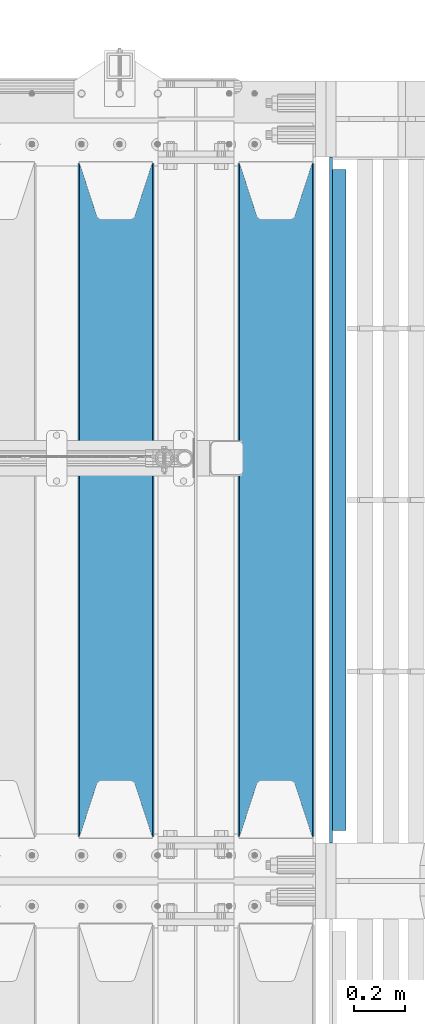
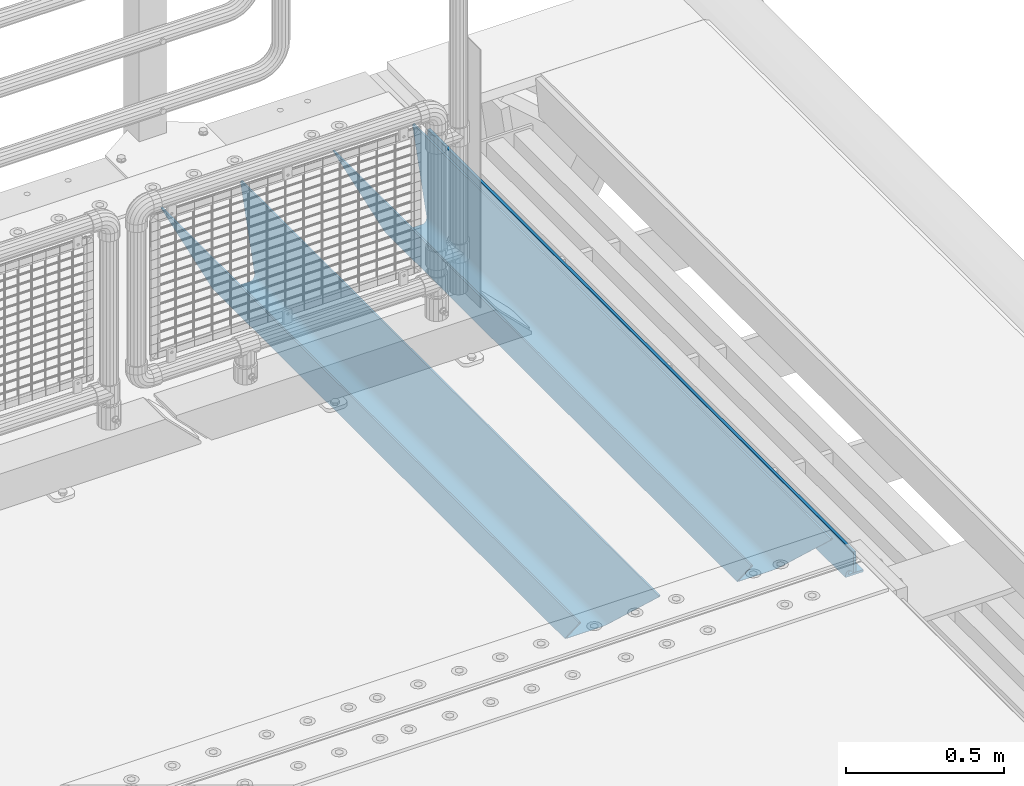
# One storey, part 135 of 247: 3 beams.
"""IFC2X3 building model written with IfcOpenShell, lengths in millimetres."""

from ifc_helpers import new_model, si_unit, frame, origin_with_axes, place, context, subcontext, project, spatial, faceted_brep, material, type_object, element, save


model = new_model("IFC2X3")

# Units and contexts
model_context = context("Model", 3, precision=1e-05, world=origin_with_axes())
body_context = subcontext(model_context, "Body", "Model", "MODEL_VIEW")
ifc_project = project(units=[si_unit("LENGTHUNIT", "METRE", prefix="MILLI"), si_unit("AREAUNIT", "SQUARE_METRE"), si_unit("VOLUMEUNIT", "CUBIC_METRE"), si_unit("MASSUNIT", "GRAM", prefix="KILO"), si_unit("TIMEUNIT", "SECOND"), si_unit("PLANEANGLEUNIT", "RADIAN"), si_unit("SOLIDANGLEUNIT", "STERADIAN"), si_unit("THERMODYNAMICTEMPERATUREUNIT", "DEGREE_CELSIUS"), si_unit("LUMINOUSINTENSITYUNIT", "LUMEN")], contexts=[model_context])

# Site, building, storey
site_placement = place(None, origin_with_axes())
site = spatial("IfcSite", under=ifc_project, at=site_placement, CompositionType="ELEMENT")
building_placement = place(site_placement, origin_with_axes())
building = spatial("IfcBuilding", under=site, at=building_placement, Name="Standard", CompositionType="ELEMENT")
storey_placement = place(building_placement, origin_with_axes())
storey = spatial("IfcBuildingStorey", under=building, at=storey_placement, Name="Undefined", CompositionType="ELEMENT", Elevation=0.0)

# Beams
ifc_material_1 = material(Name="STEEL/S355N")
beam_type_1 = type_object("IfcBeamType", PredefinedType="NOTDEFINED")
beam_1_placement = place(storey_placement, frame((16660.0, 6175.0, -115.0), z_axis=(0.0, 0.0, 1.0), x_axis=(0.0, 1.0, 0.0)))
element("IfcBeam", 1, at=beam_1_placement, inside=storey, type_object=beam_type_1, material=ifc_material_1, context=body_context, shape_type="Brep", body=[
    faceted_brep([(0.0, 150.0, 115.0), (0.0, 143.689999999999, 115.0), (2650.00000000297, 143.689999999999, 115.0), (2650.00000000297, 150.0, 115.0), (2650.00000000297, 142.059565218402, 110.0000000031), (2650.00000000297, 148.369565218403, 110.0000000031), (2441.90079219208, -80.1103600731112, -98.0992078077845), (2437.7588105432, -77.5672621345584, -102.241189456673), (2434.06523489746, -74.4080125315522, -105.934765102404), (2430.91086095089, -70.710272125576, -109.089139048974), (2428.37322971128, -66.5649389910068, -111.626770288588), (2426.51472138054, -62.0739139532889, -113.485278619323), (2425.38102192091, -57.3475956567672, -114.618978078955), (2424.99999999987, -52.5021667386536, -115.0), (2424.99999999987, 52.5021667386536, -115.0), (2425.38102192091, 57.3475956567672, -114.618978078955), (2426.51472138054, 62.0739139532889, -113.485278619323), (2428.37322971128, 66.5649389910068, -111.626770288588), (2430.91086095089, 70.710272125576, -109.089139048974), (2434.06523489746, 74.4080125315522, -105.934765102404), (2437.7588105432, 77.5672621345584, -102.241189456673), (2441.90079219208, 80.1103600731112, -98.0992078077846), (2446.38936140511, 81.9747917625791, -93.6106385947584), (2448.24948500409, 76.2713538057251, -91.7505149957729), (2444.62967112262, 74.76777986261, -95.3703288772456), (2441.28936334126, 72.7168944282894, -98.710636658607), (2438.31067330438, 70.1691124903846, -101.689326695487), (2435.76682334747, 67.1870637758839, -104.233176652398), (2433.72034654133, 63.8440531834895, -106.279653458539), (2432.22154950041, 60.222258798236, -107.778450499454), (2431.30727574265, 56.4107117849089, -108.692724257221), (2430.99999999987, 52.5031078186876, -109.0), (2430.99999999987, -52.5031078186876, -109.0), (2431.30727574265, -56.4107117849089, -108.692724257221), (2432.22154950041, -60.222258798236, -107.778450499454), (2433.72034654133, -63.8440531834895, -106.279653458539), (2435.76682334747, -67.1870637758839, -104.233176652398), (2438.31067330438, -70.1691124903846, -101.689326695487), (2441.28936334126, -72.7168944282894, -98.7106366586071), (2444.62967112262, -74.76777986261, -95.3703288772457), (2448.24948500409, -76.2713538057251, -91.7505149957729), (2650.00000000297, -142.059565218402, 110.0000000031), (2650.00000000297, -148.369565218403, 110.0000000031), (2446.38936140511, -81.9747917625791, -93.6106385947584), (2650.00000000297, -143.689999999999, 115.0), (2650.00000000297, -150.0, 115.0), (0.0, -143.689999999999, 115.0), (0.0, -150.0, 115.0), (0.0, -148.369565218261, 110.000000002663), (203.610638597422, -81.9747917625791, -93.6106385947584), (208.099207810448, -80.1103600731112, -98.0992078077845), (212.241189459336, -77.5672621345584, -102.241189456673), (215.934765105068, -74.4080125315522, -105.934765102404), (219.089139051637, -70.710272125576, -109.089139048974), (221.626770291251, -66.5649389910068, -111.626770288588), (223.485278621985, -62.0739139532889, -113.485278619323), (224.618978081617, -57.3475956567672, -114.618978078955), (225.000000002663, -52.5021667386536, -115.0), (225.000000002663, 52.5021667386536, -115.0), (224.618978081617, 57.3475956567672, -114.618978078955), (223.485278621985, 62.0739139532889, -113.485278619323), (221.626770291251, 66.5649389910068, -111.626770288588), (219.089139051637, 70.710272125576, -109.089139048974), (215.934765105068, 74.4080125315522, -105.934765102404), (212.241189459336, 77.5672621345584, -102.241189456673), (208.099207810448, 80.1103600731112, -98.0992078077846), (203.610638597422, 81.9747917625791, -93.6106385947584), (0.0, 148.369565218261, 110.000000002663), (0.0, 142.05956521826, 110.000000002663), (201.750514998436, 76.2713538057251, -91.7505149957729), (205.370328879908, 74.76777986261, -95.3703288772456), (208.710636661271, 72.7168944282894, -98.710636658607), (211.68932669815, 70.1691124903846, -101.689326695487), (214.233176655061, 67.1870637758839, -104.233176652398), (216.279653461202, 63.8440531834895, -106.279653458539), (217.778450502117, 60.222258798236, -107.778450499454), (218.692724259885, 56.4107117849089, -108.692724257221), (219.000000002663, 52.5031078186876, -109.0), (219.000000002663, -52.5031078186876, -109.0), (218.692724259885, -56.4107117849089, -108.692724257221), (217.778450502117, -60.222258798236, -107.778450499454), (216.279653461202, -63.8440531834895, -106.279653458539), (214.233176655061, -67.1870637758839, -104.233176652398), (211.68932669815, -70.1691124903846, -101.689326695487), (208.710636661271, -72.7168944282894, -98.7106366586071), (205.370328879908, -74.76777986261, -95.3703288772457), (201.750514998436, -76.2713538057251, -91.7505149957729), (0.0, -142.05956521826, 110.000000002663)], [[[0, 1, 2, 3]], [[3, 2, 4, 5]], [[6, 7, 8, 9, 10, 11, 12, 13, 14, 15, 16, 17, 18, 19, 20, 21, 22, 5, 4, 23, 24, 25, 26, 27, 28, 29, 30, 31, 32, 33, 34, 35, 36, 37, 38, 39, 40, 41, 42, 43]], [[44, 45, 42, 41]], [[46, 47, 45, 44]], [[43, 42, 45, 47, 48, 49]], [[6, 43, 49, 50]], [[7, 6, 50, 51]], [[8, 7, 51, 52]], [[9, 8, 52, 53]], [[10, 9, 53, 54]], [[11, 10, 54, 55]], [[12, 11, 55, 56]], [[13, 12, 56, 57]], [[14, 13, 57, 58]], [[15, 14, 58, 59]], [[16, 15, 59, 60]], [[17, 16, 60, 61]], [[18, 17, 61, 62]], [[19, 18, 62, 63]], [[20, 19, 63, 64]], [[21, 20, 64, 65]], [[22, 21, 65, 66]], [[0, 3, 5, 22, 66, 67]], [[1, 0, 67, 68]], [[23, 4, 2, 1, 68, 69]], [[24, 23, 69, 70]], [[25, 24, 70, 71]], [[26, 25, 71, 72]], [[27, 26, 72, 73]], [[28, 27, 73, 74]], [[29, 28, 74, 75]], [[30, 29, 75, 76]], [[31, 30, 76, 77]], [[32, 31, 77, 78]], [[33, 32, 78, 79]], [[34, 33, 79, 80]], [[35, 34, 80, 81]], [[36, 35, 81, 82]], [[37, 36, 82, 83]], [[38, 37, 83, 84]], [[39, 38, 84, 85]], [[40, 39, 85, 86]], [[46, 44, 41, 40, 86, 87]], [[47, 46, 87, 48]], [[86, 85, 84, 83, 82, 81, 80, 79, 78, 77, 76, 75, 74, 73, 72, 71, 70, 69, 68, 67, 66, 65, 64, 63, 62, 61, 60, 59, 58, 57, 56, 55, 54, 53, 52, 51, 50, 49, 48, 87]]]),
])
beam_2_placement = place(storey_placement, frame((16030.0, 6175.0, -115.0), z_axis=(0.0, 0.0, 1.0), x_axis=(0.0, 1.0, 0.0)))
element("IfcBeam", 2, at=beam_2_placement, inside=storey, type_object=beam_type_1, material=ifc_material_1, context=body_context, shape_type="Brep", body=[
    faceted_brep([(0.0, 150.0, 115.0), (0.0, 143.689999999999, 115.0), (2650.00000000297, 143.689999999999, 115.0), (2650.00000000297, 150.0, 115.0), (2650.00000000297, 142.059565218402, 110.0000000031), (2650.00000000297, 148.369565218403, 110.0000000031), (2441.90079219208, -80.1103600731112, -98.0992078077845), (2437.7588105432, -77.5672621345584, -102.241189456673), (2434.06523489746, -74.4080125315522, -105.934765102404), (2430.91086095089, -70.710272125576, -109.089139048974), (2428.37322971128, -66.5649389910068, -111.626770288588), (2426.51472138054, -62.0739139532889, -113.485278619323), (2425.38102192091, -57.3475956567672, -114.618978078955), (2424.99999999987, -52.5021667386536, -115.0), (2424.99999999987, 52.5021667386536, -115.0), (2425.38102192091, 57.3475956567672, -114.618978078955), (2426.51472138054, 62.0739139532889, -113.485278619323), (2428.37322971128, 66.5649389910068, -111.626770288588), (2430.91086095089, 70.710272125576, -109.089139048974), (2434.06523489746, 74.4080125315522, -105.934765102404), (2437.7588105432, 77.5672621345584, -102.241189456673), (2441.90079219208, 80.1103600731112, -98.0992078077846), (2446.38936140511, 81.9747917625791, -93.6106385947584), (2448.24948500409, 76.2713538057251, -91.7505149957729), (2444.62967112262, 74.76777986261, -95.3703288772456), (2441.28936334126, 72.7168944282894, -98.710636658607), (2438.31067330438, 70.1691124903846, -101.689326695487), (2435.76682334747, 67.1870637758839, -104.233176652398), (2433.72034654133, 63.8440531834895, -106.279653458539), (2432.22154950041, 60.222258798236, -107.778450499454), (2431.30727574265, 56.4107117849089, -108.692724257221), (2430.99999999987, 52.5031078186876, -109.0), (2430.99999999987, -52.5031078186876, -109.0), (2431.30727574265, -56.4107117849089, -108.692724257221), (2432.22154950041, -60.222258798236, -107.778450499454), (2433.72034654133, -63.8440531834895, -106.279653458539), (2435.76682334747, -67.1870637758839, -104.233176652398), (2438.31067330438, -70.1691124903846, -101.689326695487), (2441.28936334126, -72.7168944282894, -98.7106366586071), (2444.62967112262, -74.76777986261, -95.3703288772457), (2448.24948500409, -76.2713538057251, -91.7505149957729), (2650.00000000297, -142.059565218402, 110.0000000031), (2650.00000000297, -148.369565218403, 110.0000000031), (2446.38936140511, -81.9747917625791, -93.6106385947584), (2650.00000000297, -143.689999999999, 115.0), (2650.00000000297, -150.0, 115.0), (0.0, -143.689999999999, 115.0), (0.0, -150.0, 115.0), (0.0, -148.369565218261, 110.000000002663), (203.610638597422, -81.9747917625791, -93.6106385947584), (208.099207810448, -80.1103600731112, -98.0992078077845), (212.241189459336, -77.5672621345584, -102.241189456673), (215.934765105068, -74.4080125315522, -105.934765102404), (219.089139051637, -70.710272125576, -109.089139048974), (221.626770291251, -66.5649389910068, -111.626770288588), (223.485278621985, -62.0739139532889, -113.485278619323), (224.618978081617, -57.3475956567672, -114.618978078955), (225.000000002663, -52.5021667386536, -115.0), (225.000000002663, 52.5021667386536, -115.0), (224.618978081617, 57.3475956567672, -114.618978078955), (223.485278621985, 62.0739139532889, -113.485278619323), (221.626770291251, 66.5649389910068, -111.626770288588), (219.089139051637, 70.710272125576, -109.089139048974), (215.934765105068, 74.4080125315522, -105.934765102404), (212.241189459336, 77.5672621345584, -102.241189456673), (208.099207810448, 80.1103600731112, -98.0992078077846), (203.610638597422, 81.9747917625791, -93.6106385947584), (0.0, 148.369565218261, 110.000000002663), (0.0, 142.05956521826, 110.000000002663), (201.750514998436, 76.2713538057251, -91.7505149957729), (205.370328879908, 74.76777986261, -95.3703288772456), (208.710636661271, 72.7168944282894, -98.710636658607), (211.68932669815, 70.1691124903846, -101.689326695487), (214.233176655061, 67.1870637758839, -104.233176652398), (216.279653461202, 63.8440531834895, -106.279653458539), (217.778450502117, 60.222258798236, -107.778450499454), (218.692724259885, 56.4107117849089, -108.692724257221), (219.000000002663, 52.5031078186876, -109.0), (219.000000002663, -52.5031078186876, -109.0), (218.692724259885, -56.4107117849089, -108.692724257221), (217.778450502117, -60.222258798236, -107.778450499454), (216.279653461202, -63.8440531834895, -106.279653458539), (214.233176655061, -67.1870637758839, -104.233176652398), (211.68932669815, -70.1691124903846, -101.689326695487), (208.710636661271, -72.7168944282894, -98.7106366586071), (205.370328879908, -74.76777986261, -95.3703288772457), (201.750514998436, -76.2713538057251, -91.7505149957729), (0.0, -142.05956521826, 110.000000002663)], [[[0, 1, 2, 3]], [[3, 2, 4, 5]], [[6, 7, 8, 9, 10, 11, 12, 13, 14, 15, 16, 17, 18, 19, 20, 21, 22, 5, 4, 23, 24, 25, 26, 27, 28, 29, 30, 31, 32, 33, 34, 35, 36, 37, 38, 39, 40, 41, 42, 43]], [[44, 45, 42, 41]], [[46, 47, 45, 44]], [[43, 42, 45, 47, 48, 49]], [[6, 43, 49, 50]], [[7, 6, 50, 51]], [[8, 7, 51, 52]], [[9, 8, 52, 53]], [[10, 9, 53, 54]], [[11, 10, 54, 55]], [[12, 11, 55, 56]], [[13, 12, 56, 57]], [[14, 13, 57, 58]], [[15, 14, 58, 59]], [[16, 15, 59, 60]], [[17, 16, 60, 61]], [[18, 17, 61, 62]], [[19, 18, 62, 63]], [[20, 19, 63, 64]], [[21, 20, 64, 65]], [[22, 21, 65, 66]], [[0, 3, 5, 22, 66, 67]], [[1, 0, 67, 68]], [[23, 4, 2, 1, 68, 69]], [[24, 23, 69, 70]], [[25, 24, 70, 71]], [[26, 25, 71, 72]], [[27, 26, 72, 73]], [[28, 27, 73, 74]], [[29, 28, 74, 75]], [[30, 29, 75, 76]], [[31, 30, 76, 77]], [[32, 31, 77, 78]], [[33, 32, 78, 79]], [[34, 33, 79, 80]], [[35, 34, 80, 81]], [[36, 35, 81, 82]], [[37, 36, 82, 83]], [[38, 37, 83, 84]], [[39, 38, 84, 85]], [[40, 39, 85, 86]], [[46, 44, 41, 40, 86, 87]], [[47, 46, 87, 48]], [[86, 85, 84, 83, 82, 81, 80, 79, 78, 77, 76, 75, 74, 73, 72, 71, 70, 69, 68, 67, 66, 65, 64, 63, 62, 61, 60, 59, 58, 57, 56, 55, 54, 53, 52, 51, 50, 49, 48, 87]]]),
])
ifc_material_2 = material(Name="STEEL/S355J2")
beam_type_2 = type_object("IfcBeamType", PredefinedType="NOTDEFINED")
beam_3_placement = place(storey_placement, frame((16904.5025260065, 6150.0, -124.999999999993), z_axis=(0.0, 0.0, 1.0), x_axis=(0.0, 1.0, 0.0)))
element("IfcBeam", 3, at=beam_3_placement, inside=storey, type_object=beam_type_2, material=ifc_material_2, context=body_context, shape_type="Brep", body=[
    faceted_brep([(2700.0, 22.5, -15.0), (2684.54915028125, 22.5, -17.4471741852423), (2684.54915028125, 32.5, -17.4471741852423), (2700.0, 32.5, -15.0), (2670.61073738538, 22.5, -24.5491502812526), (2670.61073738538, 32.5, -24.5491502812526), (2659.54915028125, 22.5, -35.6107373853764), (2659.54915028125, 32.5, -35.6107373853764), (2652.44717418524, 22.5, -49.5491502812526), (2652.44717418524, 32.5, -49.5491502812526), (2651.58384440324, -32.5, -55.0), (2650.0, -32.5, -65.0), (2650.0, 32.5, -65.0), (2651.58384440324, 22.5, -55.0), (0.0, 32.5, 65.0), (0.0, 22.5, 65.0), (2700.0, 22.5, 65.0), (2700.0, 32.5, 65.0), (0.0, 32.5, -15.0), (0.0, 22.5, -15.0), (15.4508497187474, 32.5, -17.4471741852423), (15.4508497187474, 22.5, -17.4471741852423), (29.3892626146236, 32.5, -24.5491502812526), (29.3892626146236, 22.5, -24.5491502812526), (40.4508497187473, 32.5, -35.6107373853763), (40.4508497187473, 22.5, -35.6107373853763), (47.5528258147577, 32.5, -49.5491502812526), (47.5528258147577, 22.5, -49.5491502812526), (50.0, -32.5, -65.0), (48.4161555967548, -32.5, -55.0), (48.4161555967548, 22.5, -55.0), (50.0, 32.5, -65.0)], [[[0, 1, 2, 3]], [[4, 5, 2, 1]], [[6, 7, 5, 4]], [[8, 9, 7, 6]], [[10, 11, 12, 9, 8, 13]], [[14, 15, 16, 17]], [[15, 14, 18, 19]], [[19, 18, 20, 21]], [[21, 20, 22, 23]], [[23, 22, 24, 25]], [[25, 24, 26, 27]], [[28, 29, 30, 27, 26, 31]], [[30, 29, 10, 13]], [[16, 15, 19, 21, 23, 25, 27, 30, 13, 8, 6, 4, 1, 0]], [[17, 16, 0, 3]], [[5, 7, 9, 12, 31, 26, 24, 22, 20, 18, 14, 17, 3, 2]], [[28, 31, 12, 11]], [[29, 28, 11, 10]]]),
])

save(model, "model.ifc")
